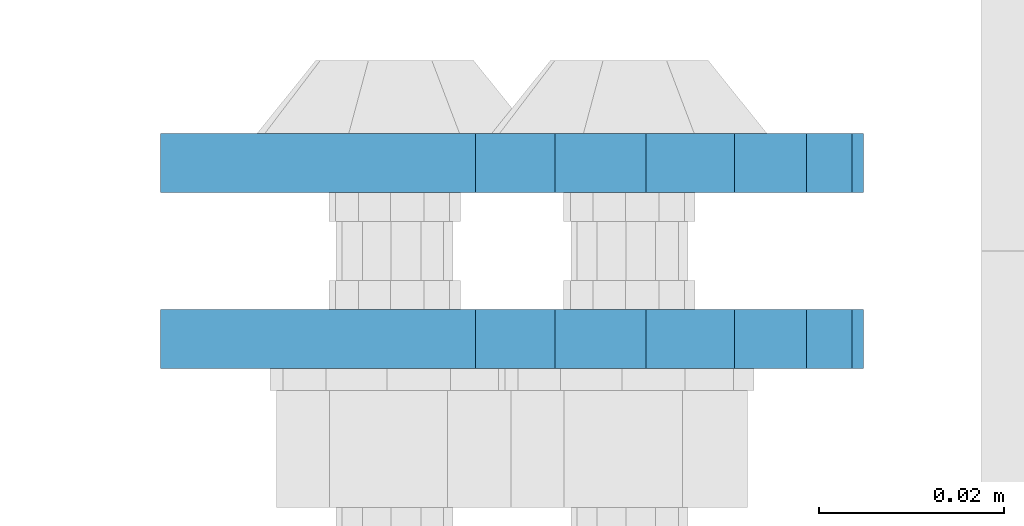
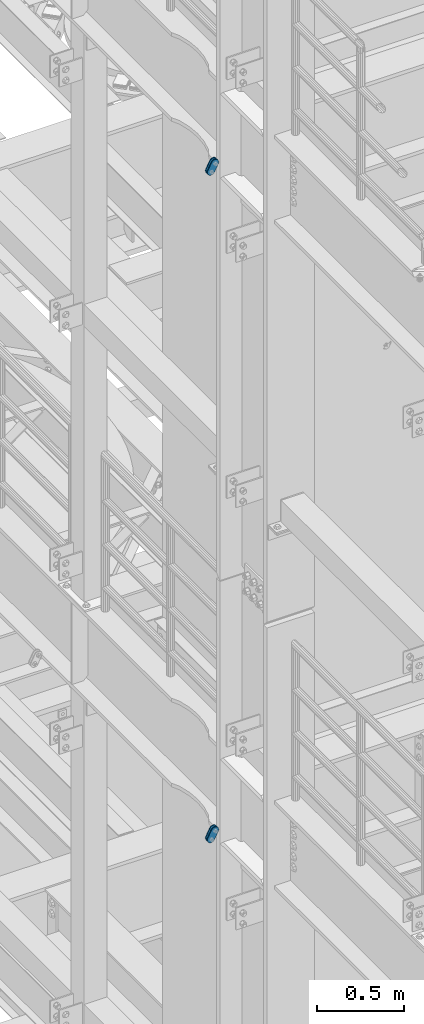
# One storey, part 1544 of 1876: 4 plates, 4 elements without a shape of their own.
"""IFC2X3 building model written with IfcOpenShell, lengths in millimetres."""

from ifc_helpers import new_model, si_unit, frame, origin_with_axes, place, context, subcontext, project, spatial, faceted_brep, material, type_object, element, aggregate, save


model = new_model("IFC2X3")

# Units and contexts
model_context = context("Model", 3, precision=1e-05, world=origin_with_axes())
body_context = subcontext(model_context, "Body", "Model", "MODEL_VIEW")
ifc_project = project(units=[si_unit("LENGTHUNIT", "METRE", prefix="MILLI"), si_unit("AREAUNIT", "SQUARE_METRE"), si_unit("VOLUMEUNIT", "CUBIC_METRE"), si_unit("MASSUNIT", "GRAM", prefix="KILO"), si_unit("TIMEUNIT", "SECOND"), si_unit("PLANEANGLEUNIT", "RADIAN"), si_unit("SOLIDANGLEUNIT", "STERADIAN"), si_unit("THERMODYNAMICTEMPERATUREUNIT", "DEGREE_CELSIUS"), si_unit("LUMINOUSINTENSITYUNIT", "LUMEN")], contexts=[model_context])

# Site, building, storey
site_placement = place(None, origin_with_axes())
site = spatial("IfcSite", under=ifc_project, at=site_placement, CompositionType="ELEMENT")
building_placement = place(site_placement, origin_with_axes())
building = spatial("IfcBuilding", under=site, at=building_placement, Name="Undefined", CompositionType="ELEMENT")
storey_placement = place(building_placement, origin_with_axes())
storey = spatial("IfcBuildingStorey", under=building, at=storey_placement, Name="Undefined", CompositionType="ELEMENT", Elevation=0.0)

# Assembly, plate
assembly_1_placement = place(storey_placement, origin_with_axes())
assembly_1 = element("IfcElementAssembly", 1, at=assembly_1_placement, inside=storey, Name="PLATE", AssemblyPlace="NOTDEFINED", PredefinedType="RIGID_FRAME")
ifc_material = material(Name="STEEL/A36")
plate_type = type_object("IfcPlateType", PredefinedType="NOTDEFINED")
plate_1_placement = place(assembly_1_placement, frame((-354.259224851121, 1514.47500379472, 17725.1776774809), z_axis=(0.894427191199916, 0.0, -0.447213595099958), x_axis=(-0.447213595099961, 6.99999707257306e-09, -0.894427191199915)))
plate_1 = element("IfcPlate", 2, at=plate_1_placement, type_object=plate_type, material=ifc_material, Name="PLATE", context=body_context, shape_type="Brep", body=[
    faceted_brep([(-8.59611645864788e-07, -3.17499999999654, 25.3999987589127), (1.93345873884391, -3.17499999999382, 35.1201580589886), (1.93345873884391, 3.17500000000564, 35.1201580589886), (-8.59611645864788e-07, 3.17500000000382, 25.3999987589132), (7.43948648259902, -3.17499999999109, 43.3605112870105), (7.43948648259902, 3.17500000000928, 43.3605112870105), (15.6798395242777, -3.17499999998654, 48.8665393096448), (15.6798395242777, 3.17500000001382, 48.8665393096448), (25.3999987589095, -3.17499999998199, 50.7999992370592), (25.3999987589095, 3.17500000001837, 50.7999992370592), (82.196130752618, -3.17499999998381, 50.7999992370605), (82.196130752618, 3.17500000001655, 50.7999992370642), (91.9162897887145, -3.17499999997926, 48.8665393918873), (91.9162897887145, 3.1750000000211, 48.8665393918909), (100.156642725027, -3.17499999997472, 43.3605115909359), (100.156642725027, 3.17500000002565, 43.3605115909395), (105.662670525982, -3.17499999997108, 35.1201586546285), (105.662670525986, 3.17500000002929, 35.1201586546358), (107.596130371159, -3.17499999996744, 25.3999996185757), (107.596130371159, 3.17500000003292, 25.3999996185794), (105.662670525981, -3.17499999996471, 15.6798405824902), (105.662670525981, 3.17500000003565, 15.6798405824939), (100.156642725024, -3.17499999996471, 7.43948764618654), (100.156642725025, 3.17500000003565, 7.43948764619017), (91.9162897887127, -3.17499999996562, 1.93345984522784), (91.9162897887127, 3.17500000003474, 1.93345984523148), (82.196130752618, -3.17499999996835, 4.54747350886464e-11), (82.196130752618, 3.1750000000311, 4.91127138957381e-11), (25.399998758905, -3.17499999999018, -8.64019966684282e-12), (25.399998758905, 3.17500000001019, -8.64019966684282e-12), (15.679839921364, -3.17499999999382, 1.9334597629304), (15.679839921364, 3.17500000000655, 1.9334597629304), (7.43948709043525, -3.17499999999654, 7.43948734220839), (7.43948709043525, 3.17500000000382, 7.43948734220885), (1.93345923228208, -3.17499999999654, 15.6798399868012), (1.93345923228208, 3.17500000000291, 15.6798399868012)], [[[0, 1, 2, 3]], [[1, 4, 5, 2]], [[4, 6, 7, 5]], [[6, 8, 9, 7]], [[8, 10, 11, 9]], [[10, 12, 13, 11]], [[12, 14, 15, 13]], [[14, 16, 17, 15]], [[16, 18, 19, 17]], [[18, 20, 21, 19]], [[20, 22, 23, 21]], [[22, 24, 25, 23]], [[24, 26, 27, 25]], [[26, 28, 29, 27]], [[28, 30, 31, 29]], [[30, 32, 33, 31]], [[32, 34, 35, 33]], [[34, 0, 3, 35]], [[5, 7, 9, 11, 13, 15, 17, 19, 21, 23, 25, 27, 29, 31, 33, 35, 3, 2]], [[34, 32, 30, 28, 26, 24, 22, 20, 18, 16, 14, 12, 10, 8, 6, 4, 1, 0]]]),
])
aggregate(assembly_1, [plate_1])

assembly_2_placement = place(storey_placement, origin_with_axes())
assembly_2 = element("IfcElementAssembly", 3, at=assembly_2_placement, inside=storey, Name="PLATE", AssemblyPlace="NOTDEFINED", PredefinedType="RIGID_FRAME")
plate_2_placement = place(assembly_2_placement, frame((-354.259224851121, 1533.5362000994, 17725.1776774809), z_axis=(0.894427191199916, 0.0, -0.447213595099958), x_axis=(-0.447213595099961, 6.99999707257306e-09, -0.894427191199915)))
plate_2 = element("IfcPlate", 4, at=plate_2_placement, type_object=plate_type, material=ifc_material, Name="PLATE", context=body_context, shape_type="Brep", body=[
    faceted_brep([(-8.59611645864788e-07, -3.17499999999654, 25.3999987589127), (1.93345873884391, -3.17499999999382, 35.1201580589886), (1.93345873884391, 3.17500000000564, 35.1201580589886), (-8.59611645864788e-07, 3.17500000000382, 25.3999987589132), (7.43948648259902, -3.17499999999109, 43.3605112870105), (7.43948648259902, 3.17500000000928, 43.3605112870105), (15.6798395242777, -3.17499999998654, 48.8665393096448), (15.6798395242777, 3.17500000001382, 48.8665393096448), (25.3999987589095, -3.17499999998199, 50.7999992370592), (25.3999987589095, 3.17500000001837, 50.7999992370592), (82.196130752618, -3.17499999998381, 50.7999992370605), (82.196130752618, 3.17500000001655, 50.7999992370642), (91.9162897887145, -3.17499999997926, 48.8665393918873), (91.9162897887145, 3.1750000000211, 48.8665393918909), (100.156642725027, -3.17499999997472, 43.3605115909359), (100.156642725027, 3.17500000002565, 43.3605115909395), (105.662670525982, -3.17499999997108, 35.1201586546285), (105.662670525986, 3.17500000002929, 35.1201586546358), (107.596130371159, -3.17499999996744, 25.3999996185757), (107.596130371159, 3.17500000003292, 25.3999996185794), (105.662670525981, -3.17499999996471, 15.6798405824902), (105.662670525981, 3.17500000003565, 15.6798405824939), (100.156642725024, -3.17499999996471, 7.43948764618654), (100.156642725025, 3.17500000003565, 7.43948764619017), (91.9162897887127, -3.17499999996562, 1.93345984522784), (91.9162897887127, 3.17500000003474, 1.93345984523148), (82.196130752618, -3.17499999996835, 4.54747350886464e-11), (82.196130752618, 3.1750000000311, 4.91127138957381e-11), (25.399998758905, -3.17499999999018, -8.64019966684282e-12), (25.399998758905, 3.17500000001019, -8.64019966684282e-12), (15.679839921364, -3.17499999999382, 1.9334597629304), (15.679839921364, 3.17500000000655, 1.9334597629304), (7.43948709043525, -3.17499999999654, 7.43948734220839), (7.43948709043525, 3.17500000000382, 7.43948734220885), (1.93345923228208, -3.17499999999654, 15.6798399868012), (1.93345923228208, 3.17500000000291, 15.6798399868012)], [[[0, 1, 2, 3]], [[1, 4, 5, 2]], [[4, 6, 7, 5]], [[6, 8, 9, 7]], [[8, 10, 11, 9]], [[10, 12, 13, 11]], [[12, 14, 15, 13]], [[14, 16, 17, 15]], [[16, 18, 19, 17]], [[18, 20, 21, 19]], [[20, 22, 23, 21]], [[22, 24, 25, 23]], [[24, 26, 27, 25]], [[26, 28, 29, 27]], [[28, 30, 31, 29]], [[30, 32, 33, 31]], [[32, 34, 35, 33]], [[34, 0, 3, 35]], [[5, 7, 9, 11, 13, 15, 17, 19, 21, 23, 25, 27, 29, 31, 33, 35, 3, 2]], [[34, 32, 30, 28, 26, 24, 22, 20, 18, 16, 14, 12, 10, 8, 6, 4, 1, 0]]]),
])
aggregate(assembly_2, [plate_2])

assembly_3_placement = place(storey_placement, origin_with_axes())
assembly_3 = element("IfcElementAssembly", 5, at=assembly_3_placement, inside=storey, Name="PLATE", AssemblyPlace="NOTDEFINED", PredefinedType="RIGID_FRAME")
plate_3_placement = place(assembly_3_placement, frame((-354.259224851122, 1514.47500379472, 13038.8776774809), z_axis=(0.894427191199916, 0.0, -0.447213595099958), x_axis=(-0.447213595099961, 6.99999707257306e-09, -0.894427191199915)))
plate_3 = element("IfcPlate", 6, at=plate_3_placement, type_object=plate_type, material=ifc_material, Name="PLATE", context=body_context, shape_type="Brep", body=[
    faceted_brep([(-8.59611645864788e-07, -3.17499999999654, 25.3999987589127), (1.93345873884391, -3.17499999999382, 35.1201580589886), (1.93345873884391, 3.17500000000564, 35.1201580589886), (-8.59611645864788e-07, 3.17500000000382, 25.3999987589132), (7.43948648259902, -3.17499999999109, 43.3605112870105), (7.43948648259902, 3.17500000000928, 43.3605112870105), (15.6798395242777, -3.17499999998654, 48.8665393096448), (15.6798395242777, 3.17500000001382, 48.8665393096448), (25.3999987589095, -3.17499999998199, 50.7999992370592), (25.3999987589095, 3.17500000001837, 50.7999992370592), (82.196130752618, -3.17499999998381, 50.7999992370605), (82.196130752618, 3.17500000001655, 50.7999992370642), (91.9162897887145, -3.17499999997926, 48.8665393918873), (91.9162897887145, 3.1750000000211, 48.8665393918909), (100.156642725027, -3.17499999997472, 43.3605115909359), (100.156642725027, 3.17500000002565, 43.3605115909395), (105.662670525982, -3.17499999997108, 35.1201586546285), (105.662670525986, 3.17500000002929, 35.1201586546358), (107.596130371159, -3.17499999996744, 25.3999996185757), (107.596130371159, 3.17500000003292, 25.3999996185794), (105.662670525981, -3.17499999996471, 15.6798405824902), (105.662670525981, 3.17500000003565, 15.6798405824939), (100.156642725024, -3.17499999996471, 7.43948764618654), (100.156642725025, 3.17500000003565, 7.43948764619017), (91.9162897887127, -3.17499999996562, 1.93345984522784), (91.9162897887127, 3.17500000003474, 1.93345984523148), (82.196130752618, -3.17499999996835, 4.54747350886464e-11), (82.196130752618, 3.1750000000311, 4.91127138957381e-11), (25.399998758905, -3.17499999999018, -8.64019966684282e-12), (25.399998758905, 3.17500000001019, -8.64019966684282e-12), (15.679839921364, -3.17499999999382, 1.9334597629304), (15.679839921364, 3.17500000000655, 1.9334597629304), (7.43948709043525, -3.17499999999654, 7.43948734220839), (7.43948709043525, 3.17500000000382, 7.43948734220885), (1.93345923228208, -3.17499999999654, 15.6798399868012), (1.93345923228208, 3.17500000000291, 15.6798399868012)], [[[0, 1, 2, 3]], [[1, 4, 5, 2]], [[4, 6, 7, 5]], [[6, 8, 9, 7]], [[8, 10, 11, 9]], [[10, 12, 13, 11]], [[12, 14, 15, 13]], [[14, 16, 17, 15]], [[16, 18, 19, 17]], [[18, 20, 21, 19]], [[20, 22, 23, 21]], [[22, 24, 25, 23]], [[24, 26, 27, 25]], [[26, 28, 29, 27]], [[28, 30, 31, 29]], [[30, 32, 33, 31]], [[32, 34, 35, 33]], [[34, 0, 3, 35]], [[5, 7, 9, 11, 13, 15, 17, 19, 21, 23, 25, 27, 29, 31, 33, 35, 3, 2]], [[34, 32, 30, 28, 26, 24, 22, 20, 18, 16, 14, 12, 10, 8, 6, 4, 1, 0]]]),
])
aggregate(assembly_3, [plate_3])

assembly_4_placement = place(storey_placement, origin_with_axes())
assembly_4 = element("IfcElementAssembly", 7, at=assembly_4_placement, inside=storey, Name="PLATE", AssemblyPlace="NOTDEFINED", PredefinedType="RIGID_FRAME")
plate_4_placement = place(assembly_4_placement, frame((-354.259224851122, 1533.5362000994, 13038.8776774809), z_axis=(0.894427191199916, 0.0, -0.447213595099958), x_axis=(-0.447213595099961, 6.99999707257306e-09, -0.894427191199915)))
plate_4 = element("IfcPlate", 8, at=plate_4_placement, type_object=plate_type, material=ifc_material, Name="PLATE", context=body_context, shape_type="Brep", body=[
    faceted_brep([(-8.59611645864788e-07, -3.17499999999654, 25.3999987589127), (1.93345873884391, -3.17499999999382, 35.1201580589886), (1.93345873884391, 3.17500000000564, 35.1201580589886), (-8.59611645864788e-07, 3.17500000000382, 25.3999987589132), (7.43948648259902, -3.17499999999109, 43.3605112870105), (7.43948648259902, 3.17500000000928, 43.3605112870105), (15.6798395242777, -3.17499999998654, 48.8665393096448), (15.6798395242777, 3.17500000001382, 48.8665393096448), (25.3999987589095, -3.17499999998199, 50.7999992370592), (25.3999987589095, 3.17500000001837, 50.7999992370592), (82.196130752618, -3.17499999998381, 50.7999992370605), (82.196130752618, 3.17500000001655, 50.7999992370642), (91.9162897887145, -3.17499999997926, 48.8665393918873), (91.9162897887145, 3.1750000000211, 48.8665393918909), (100.156642725027, -3.17499999997472, 43.3605115909359), (100.156642725027, 3.17500000002565, 43.3605115909395), (105.662670525982, -3.17499999997108, 35.1201586546285), (105.662670525986, 3.17500000002929, 35.1201586546358), (107.596130371159, -3.17499999996744, 25.3999996185757), (107.596130371159, 3.17500000003292, 25.3999996185794), (105.662670525981, -3.17499999996471, 15.6798405824902), (105.662670525981, 3.17500000003565, 15.6798405824939), (100.156642725024, -3.17499999996471, 7.43948764618654), (100.156642725025, 3.17500000003565, 7.43948764619017), (91.9162897887127, -3.17499999996562, 1.93345984522784), (91.9162897887127, 3.17500000003474, 1.93345984523148), (82.196130752618, -3.17499999996835, 4.54747350886464e-11), (82.196130752618, 3.1750000000311, 4.91127138957381e-11), (25.399998758905, -3.17499999999018, -8.64019966684282e-12), (25.399998758905, 3.17500000001019, -8.64019966684282e-12), (15.679839921364, -3.17499999999382, 1.9334597629304), (15.679839921364, 3.17500000000655, 1.9334597629304), (7.43948709043525, -3.17499999999654, 7.43948734220839), (7.43948709043525, 3.17500000000382, 7.43948734220885), (1.93345923228208, -3.17499999999654, 15.6798399868012), (1.93345923228208, 3.17500000000291, 15.6798399868012)], [[[0, 1, 2, 3]], [[1, 4, 5, 2]], [[4, 6, 7, 5]], [[6, 8, 9, 7]], [[8, 10, 11, 9]], [[10, 12, 13, 11]], [[12, 14, 15, 13]], [[14, 16, 17, 15]], [[16, 18, 19, 17]], [[18, 20, 21, 19]], [[20, 22, 23, 21]], [[22, 24, 25, 23]], [[24, 26, 27, 25]], [[26, 28, 29, 27]], [[28, 30, 31, 29]], [[30, 32, 33, 31]], [[32, 34, 35, 33]], [[34, 0, 3, 35]], [[5, 7, 9, 11, 13, 15, 17, 19, 21, 23, 25, 27, 29, 31, 33, 35, 3, 2]], [[34, 32, 30, 28, 26, 24, 22, 20, 18, 16, 14, 12, 10, 8, 6, 4, 1, 0]]]),
])
aggregate(assembly_4, [plate_4])

save(model, "model.ifc")
